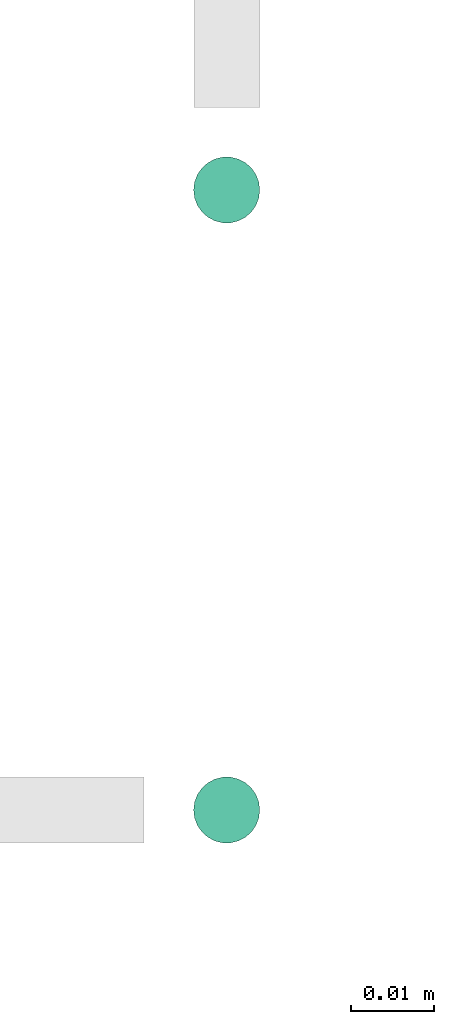
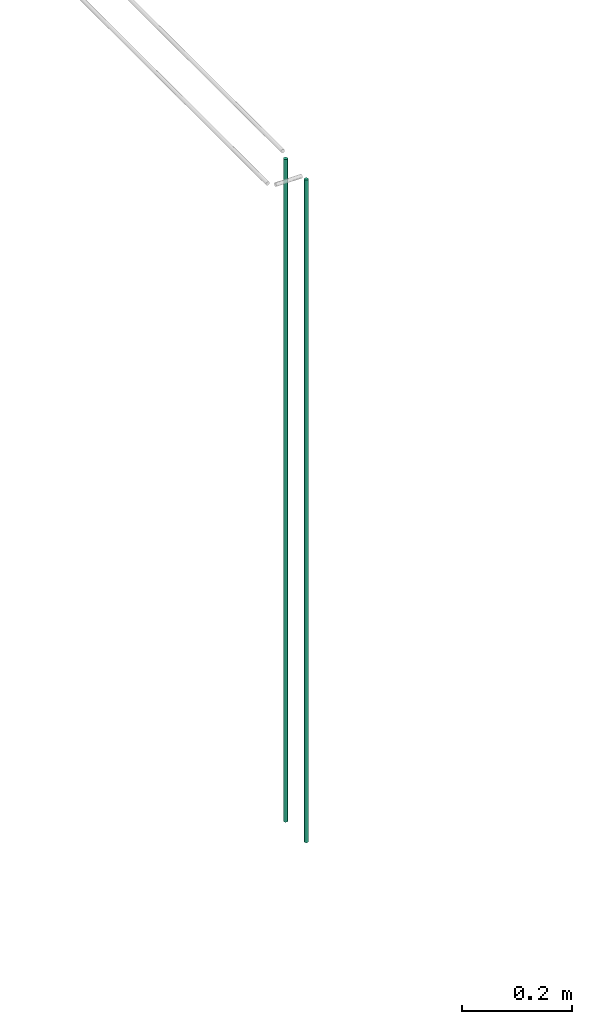
# One storey, part 29 of 89: 2 flow segments.
"""IFC2X3 building model written with IfcOpenShell, lengths in millimetres."""

from ifc_helpers import new_model, entity, si_unit, converted_unit, derived_unit, direction, frame, origin, origin_2d_with_axis, place, context, subcontext, project, spatial, circle, extrude, type_object, element, save


model = new_model("IFC2X3")

# Units and contexts
model_context = context("Model", 3, precision=0.01, world=origin(), true_north=direction((6.12303176911189e-17, 1.0)))
body_context = subcontext(model_context, "Body", "Model", "MODEL_VIEW")
ifc_project = project(units=[si_unit("LENGTHUNIT", "METRE", prefix="MILLI"), si_unit("AREAUNIT", "SQUARE_METRE"), si_unit("VOLUMEUNIT", "CUBIC_METRE"), converted_unit("PLANEANGLEUNIT", "DEGREE", entity("IfcRatioMeasure", 0.0174532925199433), si_unit("PLANEANGLEUNIT", "RADIAN"), dimensions=[0, 0, 0, 0, 0, 0, 0]), si_unit("MASSUNIT", "GRAM", prefix="KILO"), derived_unit("MASSDENSITYUNIT", [(si_unit("MASSUNIT", "GRAM", prefix="KILO"), 1), (si_unit("LENGTHUNIT", "METRE"), -3)]), derived_unit("MOMENTOFINERTIAUNIT", [(si_unit("LENGTHUNIT", "METRE"), 4)]), si_unit("TIMEUNIT", "SECOND"), si_unit("FREQUENCYUNIT", "HERTZ"), si_unit("THERMODYNAMICTEMPERATUREUNIT", "DEGREE_CELSIUS"), derived_unit("THERMALTRANSMITTANCEUNIT", [(si_unit("MASSUNIT", "GRAM", prefix="KILO"), 1), (si_unit("THERMODYNAMICTEMPERATUREUNIT", "KELVIN"), -1), (si_unit("TIMEUNIT", "SECOND"), -3)]), derived_unit("VOLUMETRICFLOWRATEUNIT", [(si_unit("LENGTHUNIT", "METRE"), 3), (si_unit("TIMEUNIT", "SECOND"), -1)]), derived_unit("MASSFLOWRATEUNIT", [(si_unit("MASSUNIT", "GRAM", prefix="KILO"), 1), (si_unit("TIMEUNIT", "SECOND"), -1)]), derived_unit("ROTATIONALFREQUENCYUNIT", [(si_unit("TIMEUNIT", "SECOND"), -1)]), si_unit("ELECTRICCURRENTUNIT", "AMPERE"), si_unit("ELECTRICVOLTAGEUNIT", "VOLT"), si_unit("POWERUNIT", "WATT"), si_unit("FORCEUNIT", "NEWTON", prefix="KILO"), si_unit("ILLUMINANCEUNIT", "LUX"), si_unit("LUMINOUSFLUXUNIT", "LUMEN"), si_unit("LUMINOUSINTENSITYUNIT", "CANDELA"), derived_unit("USERDEFINED", [(si_unit("MASSUNIT", "GRAM", prefix="KILO"), -1), (si_unit("LENGTHUNIT", "METRE"), -2), (si_unit("TIMEUNIT", "SECOND"), 3), (si_unit("LUMINOUSFLUXUNIT", "LUMEN"), 1)]), derived_unit("LINEARVELOCITYUNIT", [(si_unit("LENGTHUNIT", "METRE"), 1), (si_unit("TIMEUNIT", "SECOND"), -1)]), si_unit("PRESSUREUNIT", "PASCAL"), derived_unit("USERDEFINED", [(si_unit("LENGTHUNIT", "METRE"), -2), (si_unit("MASSUNIT", "GRAM", prefix="KILO"), 1), (si_unit("TIMEUNIT", "SECOND"), -2)]), derived_unit("LINEARFORCEUNIT", [(si_unit("MASSUNIT", "GRAM", prefix="KILO"), 1), (si_unit("LENGTHUNIT", "METRE"), 1), (si_unit("TIMEUNIT", "SECOND"), -2), (si_unit("LENGTHUNIT", "METRE"), -1)]), derived_unit("PLANARFORCEUNIT", [(si_unit("MASSUNIT", "GRAM", prefix="KILO"), 1), (si_unit("LENGTHUNIT", "METRE"), 1), (si_unit("TIMEUNIT", "SECOND"), -2), (si_unit("LENGTHUNIT", "METRE"), -2)])], contexts=[model_context])

# Site, building, storey
site_placement = place(None, frame((0.0, -0.00077364408347762, 0.0)))
site = spatial("IfcSite", under=ifc_project, at=site_placement, CompositionType="ELEMENT")
building_placement = place(site_placement, origin())
building = spatial("IfcBuilding", under=site, at=building_placement, CompositionType="ELEMENT")
storey_placement = place(building_placement, frame((0.0, 0.0, 24000.0)))
storey = spatial("IfcBuildingStorey", under=building, at=storey_placement, CompositionType="ELEMENT", Elevation=24000.0)

# Flow segments
pipe_segment_type = type_object("IfcPipeSegmentType", PredefinedType="NOTDEFINED")
flow_segment_1_placement = place(storey_placement, frame((63215.5962338766, 15044.1047532517, 1599.29030386191)))
element("IfcFlowSegment", 1, at=flow_segment_1_placement, inside=storey, type_object=pipe_segment_type, context=body_context, shape_type="SweptSolid", body=[
    extrude(circle(Radius=4.0, at=origin_2d_with_axis()), frame((5.59527223545585, 5.59527223591499, 6.08830695000506e-05)), (0.0, 0.0, 1.0), 1465.70963542596),
])
flow_segment_2_placement = place(storey_placement, frame((63215.5962338761, 14969.1047532517, 1599.29036474498)))
element("IfcFlowSegment", 2, at=flow_segment_2_placement, inside=storey, type_object=pipe_segment_type, context=body_context, shape_type="SweptSolid", body=[
    extrude(circle(Radius=4.0, at=origin_2d_with_axis()), frame((5.59527223591499, 5.59527223591499, 0.0)), (0.0, 0.0, 1.0), 1465.70963525502),
])

save(model, "model.ifc")
